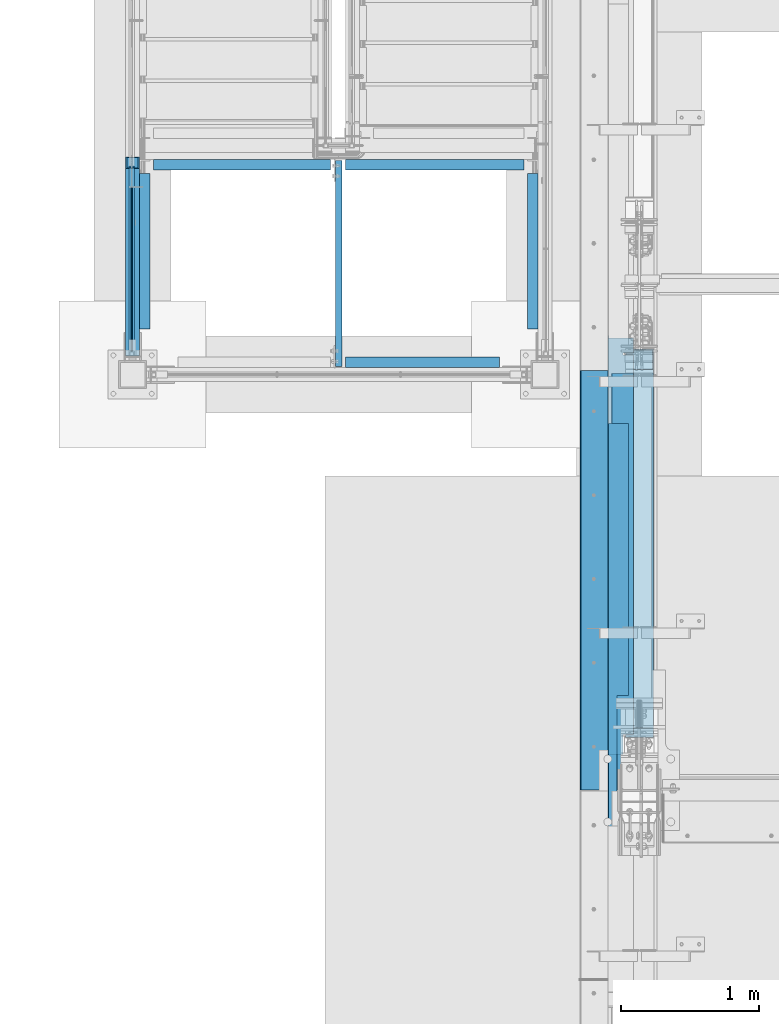
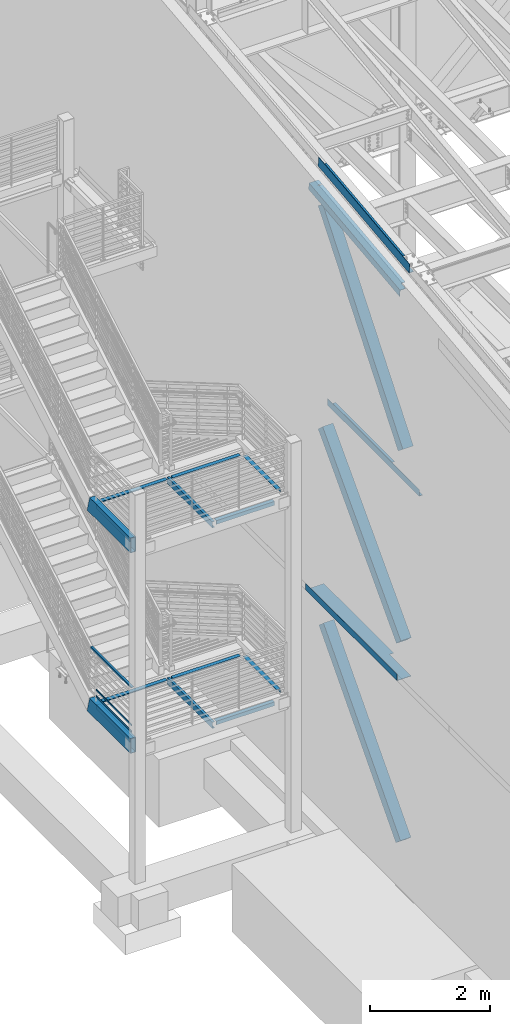
# One storey, part 729 of 1179: 21 beams, 3 members, 17 elements without a shape of their own.
"""IFC2X3 building model written with IfcOpenShell, lengths in millimetres."""

from ifc_helpers import new_model, si_unit, frame, origin_with_axes, place, context, subcontext, project, spatial, faceted_brep, material, type_object, element, aggregate, save


model = new_model("IFC2X3")

# Units and contexts
model_context = context("Model", 3, precision=1e-05, world=origin_with_axes())
body_context = subcontext(model_context, "Body", "Model", "MODEL_VIEW")
ifc_project = project(units=[si_unit("LENGTHUNIT", "METRE", prefix="MILLI"), si_unit("AREAUNIT", "SQUARE_METRE"), si_unit("VOLUMEUNIT", "CUBIC_METRE"), si_unit("MASSUNIT", "GRAM", prefix="KILO"), si_unit("TIMEUNIT", "SECOND"), si_unit("PLANEANGLEUNIT", "RADIAN"), si_unit("SOLIDANGLEUNIT", "STERADIAN"), si_unit("THERMODYNAMICTEMPERATUREUNIT", "DEGREE_CELSIUS"), si_unit("LUMINOUSINTENSITYUNIT", "LUMEN")], contexts=[model_context])

# Site, building, storey
site_placement = place(None, origin_with_axes())
site = spatial("IfcSite", under=ifc_project, at=site_placement, CompositionType="ELEMENT")
building_placement = place(site_placement, origin_with_axes())
building = spatial("IfcBuilding", under=site, at=building_placement, Name="Undefined", CompositionType="ELEMENT")
storey_placement = place(building_placement, origin_with_axes())
storey = spatial("IfcBuildingStorey", under=building, at=storey_placement, Name="Undefined", CompositionType="ELEMENT", Elevation=0.0)

# Assembly, beams
assembly_1_placement = place(storey_placement, origin_with_axes())
assembly_1 = element("IfcElementAssembly", 1, at=assembly_1_placement, inside=storey, Name="GUARDRAIL", AssemblyPlace="NOTDEFINED", PredefinedType="RIGID_FRAME")
ifc_material_1 = material(Name="STEEL/A36")
beam_type_1 = type_object("IfcBeamType", PredefinedType="NOTDEFINED")
beam_1_placement = place(assembly_1_placement, frame((-3257.54999923555, 31436.7340723971, 2406.68179561595), z_axis=(0.0, 0.0, 1.0), x_axis=(0.0, -1.0, 0.0)))
beam_1 = element("IfcBeam", 2, at=beam_1_placement, type_object=beam_type_1, material=ifc_material_1, Name="PLATE", context=body_context, shape_type="Brep", body=[
    faceted_brep([(4.76323658805632, 4.76249999999982, -19.0500000000002), (4.76323658805632, 4.76249999999982, 19.0500000000002), (1191.68407068639, 4.76249999999982, 19.0500000000002), (1191.68407068639, 4.76249999999982, -19.0500000000002), (4.76323658805632, -4.76249999999982, 19.0500000000002), (1191.68407068639, -4.76249999999982, 19.0500000000002), (4.76323658805632, -4.76249999999982, -19.0500000000002), (1191.68407068639, -4.76249999999982, -19.0500000000002)], [[[0, 1, 2, 3]], [[1, 4, 5, 2]], [[4, 6, 7, 5]], [[6, 0, 3, 7]], [[5, 7, 3, 2]], [[6, 4, 1, 0]]]),
])
beam_2_placement = place(assembly_1_placement, frame((-3257.54999923555, 31436.7340723971, 2276.50679561595), z_axis=(0.0, 0.0, 1.0), x_axis=(0.0, -1.0, 0.0)))
beam_2 = element("IfcBeam", 3, at=beam_2_placement, type_object=beam_type_1, material=ifc_material_1, Name="PLATE", context=body_context, shape_type="Brep", body=[
    faceted_brep([(4.76323658805632, 4.76249999999982, -19.0500000000002), (4.76323658805632, 4.76249999999982, 19.0500000000002), (1191.68407068639, 4.76249999999982, 19.0500000000002), (1191.68407068639, 4.76249999999982, -19.0500000000002), (4.76323658805632, -4.76249999999982, 19.0500000000002), (1191.68407068639, -4.76249999999982, 19.0500000000002), (4.76323658805632, -4.76249999999982, -19.0500000000002), (1191.68407068639, -4.76249999999982, -19.0500000000002)], [[[0, 1, 2, 3]], [[1, 4, 5, 2]], [[4, 6, 7, 5]], [[6, 0, 3, 7]], [[5, 7, 3, 2]], [[6, 4, 1, 0]]]),
])
ifc_material_2 = material()
beam_type_2 = type_object("IfcBeamType", Name="HSS1-1/2X1-1/2X1/4", PredefinedType="NOTDEFINED")
beam_3_placement = place(assembly_1_placement, frame((-3257.54999923555, 31590.0170040751, 3184.47208126713), z_axis=(0.0, 3.87960000080057e-05, 0.999999999247435), x_axis=(0.0, -0.999999999247435, 3.87960000097402e-05)))
beam_3 = element("IfcBeam", 4, at=beam_3_placement, type_object=beam_type_2, material=ifc_material_2, Name="GUARDRAIL", ObjectType="HSS1-1/2X1-1/2X1/4", context=body_context, shape_type="Brep", body=[
    faceted_brep([(1.79645228376103, 12.6999993300001, -12.6999993299992), (1.79645228376103, -12.6999993300001, -12.6999993299992), (1351.31651305502, -12.6999993300001, -12.6999993301542), (1351.31651305502, 12.6999993300001, -12.6999993301542), (8.61965151152981, -12.6999993300001, 12.6999993299983), (1376.71749714939, -12.6999993300001, 12.6999993298532), (8.61965151152981, 12.6999993300001, 12.6999993299983), (1376.71749714939, 12.6999993300001, 12.6999993298532), (0.090652412345662, 19.0499992350001, -19.0499992349992), (10.3254513829452, 19.0499992350001, 19.0499992349983), (1383.06774341299, 19.0499992350001, 19.049999234855), (1344.96626679142, 19.0499992350001, -19.049999235157), (10.3254513829452, -19.0499992350001, 19.0499992349983), (1383.06774341299, -19.0499992350001, 19.049999234855), (0.090652412345662, -19.0499992350001, -19.0499992349992), (1344.96626679142, -19.0499992350001, -19.049999235157)], [[[0, 1, 2, 3]], [[1, 4, 5, 2]], [[4, 6, 7, 5]], [[6, 0, 3, 7]], [[8, 9, 10, 11]], [[9, 12, 13, 10]], [[12, 14, 15, 13]], [[14, 8, 11, 15]], [[13, 15, 11, 10], [5, 7, 3, 2]], [[14, 12, 9, 8], [6, 4, 1, 0]]]),
])
aggregate(assembly_1, [beam_1, beam_2, beam_3])

# Assembly, beam
assembly_2_placement = place(storey_placement, origin_with_axes())
assembly_2 = element("IfcElementAssembly", 5, at=assembly_2_placement, inside=storey, Name="STRINGER", AssemblyPlace="NOTDEFINED", PredefinedType="RIGID_FRAME")
beam_type_3 = type_object("IfcBeamType", Name="L3X3X1/4", PredefinedType="NOTDEFINED")
beam_4_placement = place(assembly_2_placement, frame((-342.899999980288, 30403.7999999995, 6051.55), z_axis=(0.0, 0.0, -1.0), x_axis=(0.0, 1.0, 0.0)))
beam_4 = element("IfcBeam", 6, at=beam_4_placement, type_object=beam_type_3, material=ifc_material_1, Name="ANGLE", ObjectType="L3X3X1/4", context=body_context, shape_type="Brep", body=[
    faceted_brep([(0.0, 38.0999999999985, -38.0999999999999), (0.0, 38.0999999999985, 38.0999999999999), (1130.2999999998, 38.1, 38.1000000000004), (1130.2999999998, 38.1, -38.1000000000004), (0.0, 31.75, 38.1000000000004), (1130.2999999998, 31.75, 38.1000000000004), (0.0, 31.75, -31.75), (1130.2999999998, 31.75, -31.75), (0.0, -38.0999999999985, -31.75), (1130.2999999998, -38.1, -31.75), (0.0, -38.0999999999985, -38.0999999999999), (1130.2999999998, -38.1, -38.1000000000004)], [[[0, 1, 2, 3]], [[1, 4, 5, 2]], [[4, 6, 7, 5]], [[6, 8, 9, 7]], [[8, 10, 11, 9]], [[10, 0, 3, 11]], [[5, 7, 9, 11, 3, 2]], [[10, 8, 6, 4, 1, 0]]]),
])
aggregate(assembly_2, [beam_4])

assembly_3_placement = place(storey_placement, origin_with_axes())
assembly_3 = element("IfcElementAssembly", 7, at=assembly_3_placement, inside=storey, Name="STRINGER", AssemblyPlace="NOTDEFINED", PredefinedType="RIGID_FRAME")
beam_5_placement = place(assembly_3_placement, frame((-3162.30000000027, 30403.8, 6051.54999999882), z_axis=(1.0, 0.0, 0.0), x_axis=(0.0, 1.0, 0.0)))
beam_5 = element("IfcBeam", 8, at=beam_5_placement, type_object=beam_type_3, material=ifc_material_1, Name="ANGLE", ObjectType="L3X3X1/4", context=body_context, shape_type="Brep", body=[
    faceted_brep([(0.0, 38.0999999999985, -38.0999999999999), (0.0, 38.0999999999985, 38.0999999999999), (1130.2999999998, 38.1, 38.1000000000004), (1130.2999999998, 38.1, -38.1000000000004), (0.0, 31.75, 38.1000000000004), (1130.2999999998, 31.75, 38.1000000000004), (0.0, 31.75, -31.75), (1130.2999999998, 31.75, -31.75), (0.0, -38.0999999999985, -31.75), (1130.2999999998, -38.1, -31.75), (0.0, -38.0999999999985, -38.0999999999999), (1130.2999999998, -38.1, -38.1000000000004)], [[[0, 1, 2, 3]], [[1, 4, 5, 2]], [[4, 6, 7, 5]], [[6, 8, 9, 7]], [[8, 10, 11, 9]], [[10, 0, 3, 11]], [[5, 7, 9, 11, 3, 2]], [[10, 8, 6, 4, 1, 0]]]),
])

assembly_4_placement = place(storey_placement, origin_with_axes())
assembly_4 = element("IfcElementAssembly", 9, at=assembly_4_placement, inside=storey, Name="STRINGER", AssemblyPlace="NOTDEFINED", PredefinedType="RIGID_FRAME")
beam_6_placement = place(assembly_4_placement, frame((-3162.30000000013, 30403.8, 1978.025), z_axis=(1.0, 0.0, 0.0), x_axis=(0.0, 1.0, 0.0)))
beam_6 = element("IfcBeam", 10, at=beam_6_placement, type_object=beam_type_3, material=ifc_material_1, Name="ANGLE", ObjectType="L3X3X1/4", context=body_context, shape_type="Brep", body=[
    faceted_brep([(0.0, 38.0999999999985, -38.0999999999999), (0.0, 38.0999999999985, 38.0999999999999), (1130.2999999998, 38.1, 38.1000000000004), (1130.2999999998, 38.1, -38.1000000000004), (0.0, 31.75, 38.1000000000004), (1130.2999999998, 31.75, 38.1000000000004), (0.0, 31.75, -31.75), (1130.2999999998, 31.75, -31.75), (0.0, -38.0999999999985, -31.75), (1130.2999999998, -38.1, -31.75), (0.0, -38.0999999999985, -38.0999999999999), (1130.2999999998, -38.1, -38.1000000000004)], [[[0, 1, 2, 3]], [[1, 4, 5, 2]], [[4, 6, 7, 5]], [[6, 8, 9, 7]], [[8, 10, 11, 9]], [[10, 0, 3, 11]], [[5, 7, 9, 11, 3, 2]], [[10, 8, 6, 4, 1, 0]]]),
])

assembly_5_placement = place(storey_placement, origin_with_axes())
assembly_5 = element("IfcElementAssembly", 11, at=assembly_5_placement, inside=storey, Name="STRINGER", AssemblyPlace="NOTDEFINED", PredefinedType="RIGID_FRAME")
beam_7_placement = place(assembly_5_placement, frame((-342.900000030261, 30403.7999990904, 1978.025), z_axis=(0.0, 0.0, -1.0), x_axis=(0.0, 1.0, 0.0)))
beam_7 = element("IfcBeam", 12, at=beam_7_placement, type_object=beam_type_3, material=ifc_material_1, Name="ANGLE", ObjectType="L3X3X1/4", context=body_context, shape_type="Brep", body=[
    faceted_brep([(0.0, 38.0999999999985, -38.0999999999999), (0.0, 38.0999999999985, 38.0999999999999), (1130.2999999998, 38.1, 38.1000000000004), (1130.2999999998, 38.1, -38.1000000000004), (0.0, 31.75, 38.1000000000004), (1130.2999999998, 31.75, 38.1000000000004), (0.0, 31.75, -31.75), (1130.2999999998, 31.75, -31.75), (0.0, -38.0999999999985, -31.75), (1130.2999999998, -38.1, -31.75), (0.0, -38.0999999999985, -38.0999999999999), (1130.2999999998, -38.1, -38.1000000000004)], [[[0, 1, 2, 3]], [[1, 4, 5, 2]], [[4, 6, 7, 5]], [[6, 8, 9, 7]], [[8, 10, 11, 9]], [[10, 0, 3, 11]], [[5, 7, 9, 11, 3, 2]], [[10, 8, 6, 4, 1, 0]]]),
])
aggregate(assembly_5, [beam_7])

assembly_6_placement = place(storey_placement, origin_with_axes())
assembly_6 = element("IfcElementAssembly", 13, at=assembly_6_placement, inside=storey, Name="BEAM", AssemblyPlace="NOTDEFINED", PredefinedType="RIGID_FRAME")
beam_8_placement = place(assembly_6_placement, frame((-3098.80000000018, 31597.5999999997, 6051.54999999882), z_axis=(0.0, -1.0, 0.0), x_axis=(1.0, 0.0, 0.0)))
beam_8 = element("IfcBeam", 14, at=beam_8_placement, type_object=beam_type_3, material=ifc_material_1, Name="ANGLE", ObjectType="L3X3X1/4", context=body_context, shape_type="Brep", body=[
    faceted_brep([(0.0, 38.0999999999985, -38.0999999999999), (0.0, 38.0999999999985, 38.0999999999999), (1287.46249994958, 38.1000000000004, 38.0999999999985), (1287.46249994958, 38.1000000000004, -38.0999999999985), (0.0, 31.75, 38.1000000000004), (1287.46249994958, 31.75, 38.0999999999985), (0.0, 31.75, -31.75), (1287.46249994958, 31.75, -31.75), (0.0, -38.0999999999985, -31.75), (1287.46249994958, -38.1000000000004, -31.75), (0.0, -38.0999999999985, -38.0999999999999), (1287.46249994958, -38.1000000000004, -38.0999999999985)], [[[0, 1, 2, 3]], [[1, 4, 5, 2]], [[4, 6, 7, 5]], [[6, 8, 9, 7]], [[8, 10, 11, 9]], [[10, 0, 3, 11]], [[5, 7, 9, 11, 3, 2]], [[10, 8, 6, 4, 1, 0]]]),
])

# Assembly, beams
assembly_7_placement = place(storey_placement, origin_with_axes())
assembly_7 = element("IfcElementAssembly", 15, at=assembly_7_placement, inside=storey, Name="BEAM", AssemblyPlace="NOTDEFINED", PredefinedType="RIGID_FRAME")
beam_9_placement = place(assembly_7_placement, frame((-3098.80000000018, 31597.6, 1978.025), z_axis=(0.0, -1.0, 0.0), x_axis=(1.0, 0.0, 0.0)))
beam_9 = element("IfcBeam", 16, at=beam_9_placement, type_object=beam_type_3, material=ifc_material_1, Name="ANGLE", ObjectType="L3X3X1/4", context=body_context, shape_type="Brep", body=[
    faceted_brep([(0.0, 38.0999999999985, -38.0999999999999), (0.0, 38.0999999999985, 38.0999999999999), (1287.46249994958, 38.1000000000004, 38.0999999999985), (1287.46249994958, 38.1000000000004, -38.0999999999985), (0.0, 31.75, 38.1000000000004), (1287.46249994958, 31.75, 38.0999999999985), (0.0, 31.75, -31.75), (1287.46249994958, 31.75, -31.75), (0.0, -38.0999999999985, -31.75), (1287.46249994958, -38.1000000000004, -31.75), (0.0, -38.0999999999985, -38.0999999999999), (1287.46249994958, -38.1000000000004, -38.0999999999985)], [[[0, 1, 2, 3]], [[1, 4, 5, 2]], [[4, 6, 7, 5]], [[6, 8, 9, 7]], [[8, 10, 11, 9]], [[10, 0, 3, 11]], [[5, 7, 9, 11, 3, 2]], [[10, 8, 6, 4, 1, 0]]]),
])
beam_10_placement = place(assembly_7_placement, frame((-1703.3875, 31597.6000000001, 1978.025), z_axis=(0.0, -1.0, 0.0), x_axis=(1.0, 0.0, 0.0)))
beam_10 = element("IfcBeam", 17, at=beam_10_placement, type_object=beam_type_3, material=ifc_material_1, Name="ANGLE", ObjectType="L3X3X1/4", context=body_context, shape_type="Brep", body=[
    faceted_brep([(0.0, 38.0999999999985, -38.0999999999999), (0.0, 38.0999999999985, 38.0999999999999), (1296.98749999999, 38.0999999999999, 38.0999999999985), (1296.98749999999, 38.0999999999999, -38.0999999999985), (0.0, 31.75, 38.1000000000004), (1296.98749999999, 31.75, 38.0999999999985), (0.0, 31.75, -31.75), (1296.98749999999, 31.75, -31.75), (0.0, -38.0999999999985, -31.75), (1296.98749999999, -38.0999999999999, -31.75), (0.0, -38.0999999999985, -38.0999999999999), (1296.98749999999, -38.0999999999999, -38.0999999999985)], [[[0, 1, 2, 3]], [[1, 4, 5, 2]], [[4, 6, 7, 5]], [[6, 8, 9, 7]], [[8, 10, 11, 9]], [[10, 0, 3, 11]], [[5, 7, 9, 11, 3, 2]], [[10, 8, 6, 4, 1, 0]]]),
])
aggregate(assembly_7, [beam_9, beam_10])

# Beam
beam_11_placement = place(assembly_6_placement, frame((-1703.3875, 31597.6, 6051.55), z_axis=(0.0, -1.0, 0.0), x_axis=(1.0, 0.0, 0.0)))
beam_11 = element("IfcBeam", 18, at=beam_11_placement, type_object=beam_type_3, material=ifc_material_1, Name="ANGLE", ObjectType="L3X3X1/4", context=body_context, shape_type="Brep", body=[
    faceted_brep([(0.0, 38.0999999999985, -38.0999999999999), (0.0, 38.0999999999985, 38.0999999999999), (1296.98749999999, 38.0999999999999, 38.0999999999985), (1296.98749999999, 38.0999999999999, -38.0999999999985), (0.0, 31.75, 38.1000000000004), (1296.98749999999, 31.75, 38.0999999999985), (0.0, 31.75, -31.75), (1296.98749999999, 31.75, -31.75), (0.0, -38.0999999999985, -31.75), (1296.98749999999, -38.0999999999999, -31.75), (0.0, -38.0999999999985, -38.0999999999999), (1296.98749999999, -38.0999999999999, -38.0999999999985)], [[[0, 1, 2, 3]], [[1, 4, 5, 2]], [[4, 6, 7, 5]], [[6, 8, 9, 7]], [[8, 10, 11, 9]], [[10, 0, 3, 11]], [[5, 7, 9, 11, 3, 2]], [[10, 8, 6, 4, 1, 0]]]),
])

aggregate(assembly_6, [beam_8, beam_11])

# Assembly, beam
assembly_8_placement = place(storey_placement, origin_with_axes())
assembly_8 = element("IfcElementAssembly", 19, at=assembly_8_placement, inside=storey, Name="BEAM", AssemblyPlace="NOTDEFINED", PredefinedType="RIGID_FRAME")
beam_12_placement = place(assembly_8_placement, frame((-1703.3875, 30162.5, 1978.025), z_axis=(0.0, 0.0, -1.0), x_axis=(1.0, 0.0, 0.0)))
beam_12 = element("IfcBeam", 20, at=beam_12_placement, type_object=beam_type_3, material=ifc_material_1, Name="ANGLE", ObjectType="L3X3X1/4", context=body_context, shape_type="Brep", body=[
    faceted_brep([(0.0, 38.0999999999985, -38.0999999999999), (0.0, 38.0999999999985, 38.0999999999999), (1119.1875, 38.1000000000004, 38.0999999999985), (1119.1875, 38.1000000000004, -38.0999999999985), (0.0, 31.75, 38.1000000000004), (1119.1875, 31.75, 38.0999999999985), (0.0, 31.75, -31.75), (1119.1875, 31.75, -31.75), (0.0, -38.0999999999985, -31.75), (1119.1875, -38.1000000000004, -31.75), (0.0, -38.0999999999985, -38.0999999999999), (1119.1875, -38.1000000000004, -38.0999999999985)], [[[0, 1, 2, 3]], [[1, 4, 5, 2]], [[4, 6, 7, 5]], [[6, 8, 9, 7]], [[8, 10, 11, 9]], [[10, 0, 3, 11]], [[5, 7, 9, 11, 3, 2]], [[10, 8, 6, 4, 1, 0]]]),
])
aggregate(assembly_8, [beam_12])

assembly_9_placement = place(storey_placement, origin_with_axes())
assembly_9 = element("IfcElementAssembly", 21, at=assembly_9_placement, inside=storey, Name="BEAM", AssemblyPlace="NOTDEFINED", PredefinedType="RIGID_FRAME")
beam_13_placement = place(assembly_9_placement, frame((-1703.3875, 30162.5, 6051.55), z_axis=(0.0, 0.0, -1.0), x_axis=(1.0, 0.0, 0.0)))
beam_13 = element("IfcBeam", 22, at=beam_13_placement, type_object=beam_type_3, material=ifc_material_1, Name="ANGLE", ObjectType="L3X3X1/4", context=body_context, shape_type="Brep", body=[
    faceted_brep([(0.0, 38.0999999999985, -38.0999999999999), (0.0, 38.0999999999985, 38.0999999999999), (1119.1875, 38.1000000000004, 38.0999999999985), (1119.1875, 38.1000000000004, -38.0999999999985), (0.0, 31.75, 38.1000000000004), (1119.1875, 31.75, 38.0999999999985), (0.0, 31.75, -31.75), (1119.1875, 31.75, -31.75), (0.0, -38.0999999999985, -31.75), (1119.1875, -38.1000000000004, -31.75), (0.0, -38.0999999999985, -38.0999999999999), (1119.1875, -38.1000000000004, -38.0999999999985)], [[[0, 1, 2, 3]], [[1, 4, 5, 2]], [[4, 6, 7, 5]], [[6, 8, 9, 7]], [[8, 10, 11, 9]], [[10, 0, 3, 11]], [[5, 7, 9, 11, 3, 2]], [[10, 8, 6, 4, 1, 0]]]),
])
aggregate(assembly_9, [beam_13])

assembly_10_placement = place(storey_placement, origin_with_axes())
assembly_10 = element("IfcElementAssembly", 23, at=assembly_10_placement, inside=storey, Name="BEAM", AssemblyPlace="NOTDEFINED", PredefinedType="RIGID_FRAME")
beam_type_4 = type_object("IfcBeamType", Name="C5X9", PredefinedType="NOTDEFINED")
beam_14_placement = place(assembly_10_placement, frame((-1752.6, 30073.6, 6026.15), z_axis=(0.0, 0.0, 1.0), x_axis=(0.0, 1.0, 0.0)))
beam_14 = element("IfcBeam", 24, at=beam_14_placement, type_object=beam_type_4, material=ifc_material_1, Name="BEAM", ObjectType="C5X9", context=body_context, shape_type="Brep", body=[
    faceted_brep([(57.1499999999978, 23.8125, -63.5), (57.1499999999978, 23.8125, 63.5), (1555.75, 23.8125, 63.5), (1555.75, 23.8125, -63.5), (57.1499999999978, -23.8125, 63.5), (1555.75, -23.8125, 63.5), (57.1499999999978, -23.8125, 59.5296625000001), (1555.75, -23.8125, 59.5296625000001), (57.1499999999978, 15.875, 52.9177250000002), (1555.75, 15.875, 52.9177250000002), (57.1499999999978, 15.875, -52.9177250000002), (1555.75, 15.875, -52.9177250000002), (57.1499999999978, -23.8125, -59.5296625000001), (1555.75, -23.8125, -59.5296625000001), (57.1499999999978, -23.8125, -63.5), (1555.75, -23.8125, -63.5)], [[[0, 1, 2, 3]], [[1, 4, 5, 2]], [[4, 6, 7, 5]], [[6, 8, 9, 7]], [[8, 10, 11, 9]], [[10, 12, 13, 11]], [[12, 14, 15, 13]], [[14, 0, 3, 15]], [[5, 7, 9, 11, 13, 15, 3, 2]], [[14, 12, 10, 8, 6, 4, 1, 0]]]),
])
aggregate(assembly_10, [beam_14])

assembly_11_placement = place(storey_placement, origin_with_axes())
assembly_11 = element("IfcElementAssembly", 25, at=assembly_11_placement, inside=storey, Name="BEAM", AssemblyPlace="NOTDEFINED", PredefinedType="RIGID_FRAME")
beam_15_placement = place(assembly_11_placement, frame((-1752.6, 30073.6, 1952.625), z_axis=(0.0, 0.0, 1.0), x_axis=(0.0, 1.0, 0.0)))
beam_15 = element("IfcBeam", 26, at=beam_15_placement, type_object=beam_type_4, material=ifc_material_1, Name="BEAM", ObjectType="C5X9", context=body_context, shape_type="Brep", body=[
    faceted_brep([(57.1499999999978, 23.8125, -63.5), (57.1499999999978, 23.8125, 63.5), (1555.75, 23.8125, 63.5), (1555.75, 23.8125, -63.5), (57.1499999999978, -23.8125, 63.5), (1555.75, -23.8125, 63.5), (57.1499999999978, -23.8125, 59.5296625000001), (1555.75, -23.8125, 59.5296625000001), (57.1499999999978, 15.875, 52.9177250000002), (1555.75, 15.875, 52.9177250000002), (57.1499999999978, 15.875, -52.9177250000002), (1555.75, 15.875, -52.9177250000002), (57.1499999999978, -23.8125, -59.5296625000001), (1555.75, -23.8125, -59.5296625000001), (57.1499999999978, -23.8125, -63.5), (1555.75, -23.8125, -63.5)], [[[0, 1, 2, 3]], [[1, 4, 5, 2]], [[4, 6, 7, 5]], [[6, 8, 9, 7]], [[8, 10, 11, 9]], [[10, 12, 13, 11]], [[12, 14, 15, 13]], [[14, 0, 3, 15]], [[5, 7, 9, 11, 13, 15, 3, 2]], [[14, 12, 10, 8, 6, 4, 1, 0]]]),
])
aggregate(assembly_11, [beam_15])

assembly_12_placement = place(storey_placement, origin_with_axes())
assembly_12 = element("IfcElementAssembly", 27, at=assembly_12_placement, inside=storey, Name="BEAM", AssemblyPlace="NOTDEFINED", PredefinedType="RIGID_FRAME")
beam_type_5 = type_object("IfcBeamType", PredefinedType="NOTDEFINED")
beam_16_placement = place(assembly_12_placement, frame((388.937000000002, 28568.0759537217, 12478.2300352794), z_axis=(0.0, -0.993676146336441, -0.112284087038017), x_axis=(-1.0, 0.0, 0.0)))
beam_16 = element("IfcBeam", 28, at=beam_16_placement, type_object=beam_type_5, material=ifc_material_1, Name="BENT_PLATE", context=body_context, shape_type="Brep", body=[
    faceted_brep([(71.436748188231, -3.17500000044856, 1106.33418420742), (71.4367827558929, 3.23873428631487, 1106.33516467817), (-1.27897692436818e-11, 3.17499999954816, 1106.33518727968), (-1.27897692436818e-11, -3.17500000044856, 1106.33420675007), (71.4368094667368, -3.17499887494341, 1523.99263642799), (71.4368436902772, 3.174999999379, 1523.99999999914), (153.98700000004, -3.17499999938263, -1523.99999999915), (0.0, -3.17499999999927, -1524.0), (0.0, 3.17499999999927, -1524.0), (160.33700000004, 3.17500000061409, -1523.99999999915), (160.337000000008, -187.324999998866, -1523.99999999923), (153.987000000008, -187.324999998866, -1523.99999999923), (160.336999999976, 3.174999999379, 1523.99999999915), (160.337000000008, -187.325000000099, 1523.99999999907), (153.987000000008, -187.325000000099, 1523.99999999907), (153.986999999976, -3.17500000061773, 1523.99999999914)], [[[0, 1, 2, 3]], [[4, 5, 1, 0]], [[6, 7, 8, 9, 10, 11]], [[9, 12, 13, 10]], [[14, 11, 10, 13]], [[15, 6, 11, 14]], [[3, 7, 6, 15, 4, 0]], [[8, 7, 3, 2]], [[12, 9, 8, 2, 1, 5]], [[15, 14, 13, 12, 5, 4]]]),
])

# Beam
beam_type_6 = type_object("IfcBeamType", Name="HSS12X4X3/8", PredefinedType="NOTDEFINED")
beam_17_placement = place(assembly_3_placement, frame((-3251.20000000031, 31571.1662663812, 6089.65000000228), z_axis=(0.0, 0.0, 1.0), x_axis=(0.0, -1.0, 0.0)))
beam_17 = element("IfcBeam", 29, at=beam_17_placement, type_object=beam_type_6, material=ifc_material_2, Name="STRINGER", ObjectType="HSS12X4X3/8", context=body_context, shape_type="Brep", body=[
    faceted_brep([(-79.8273428607608, 41.2750000000015, -142.874999999865), (-79.8273428607608, -41.2750000000015, -142.874999999865), (1361.04126637977, -41.2750000000001, -142.875), (1361.04126637977, 41.2750000000001, -142.875), (-2.57507558227371, -41.2750000000015, 142.874999999935), (1361.04126637977, -41.2750000000001, 142.875), (-2.57507558227371, 41.2750000000015, 142.874999999935), (1361.04126637977, 41.2750000000001, 142.875), (-82.4024182638459, 50.8000000000002, -152.4), (0.0, 50.8000000000029, 152.4), (1361.04126637977, 50.8000000000002, 152.4), (1361.04126637977, 50.8000000000002, -152.4), (0.0, -50.8000000000029, 152.4), (1361.04126637977, -50.8000000000002, 152.4), (-82.4024182638459, -50.8000000000002, -152.4), (1361.04126637977, -50.8000000000002, -152.4)], [[[0, 1, 2, 3]], [[1, 4, 5, 2]], [[4, 6, 7, 5]], [[6, 0, 3, 7]], [[8, 9, 10, 11]], [[9, 12, 13, 10]], [[12, 14, 15, 13]], [[14, 8, 11, 15]], [[13, 15, 11, 10], [5, 7, 3, 2]], [[14, 12, 9, 8], [6, 4, 1, 0]]]),
])

aggregate(assembly_3, [beam_5, beam_17])

beam_18_placement = place(assembly_4_placement, frame((-3251.20000000004, 31571.2546584537, 2016.12499999985), z_axis=(0.0, 0.0, 1.0), x_axis=(0.0, -1.0, 0.0)))
beam_18 = element("IfcBeam", 30, at=beam_18_placement, type_object=beam_type_6, material=ifc_material_2, Name="STRINGER", ObjectType="HSS12X4X3/8", context=body_context, shape_type="Brep", body=[
    faceted_brep([(-79.3135540918956, 41.2750000000001, -142.875), (-79.3135540918956, -41.2750000000001, -142.875), (1361.22936526286, -41.2750000000001, -142.875), (1361.22936526286, 41.2750000000001, -142.875), (-2.55850173872022, -41.2750000000001, 142.875), (1361.22936526286, -41.2750000000001, 142.875), (-2.55850173872022, 41.2750000000001, 142.875), (1361.22936526286, 41.2750000000001, 142.875), (-81.8720558370042, 50.8000000000002, -152.4), (0.0, 50.8000000000029, 152.4), (1361.22936526286, 50.8000000000002, 152.4), (1361.22936526286, 50.8000000000002, -152.4), (0.0, -50.8000000000029, 152.4), (1361.22936526286, -50.8000000000002, 152.4), (-81.8720558370042, -50.8000000000002, -152.4), (1361.22936526286, -50.8000000000002, -152.4)], [[[0, 1, 2, 3]], [[1, 4, 5, 2]], [[4, 6, 7, 5]], [[6, 0, 3, 7]], [[8, 9, 10, 11]], [[9, 12, 13, 10]], [[12, 14, 15, 13]], [[14, 8, 11, 15]], [[13, 15, 11, 10], [5, 7, 3, 2]], [[14, 12, 9, 8], [6, 4, 1, 0]]]),
])

aggregate(assembly_4, [beam_6, beam_18])

# Assembly, member
assembly_13_placement = place(storey_placement, origin_with_axes())
assembly_13 = element("IfcElementAssembly", 31, at=assembly_13_placement, inside=storey, Name="None", AssemblyPlace="NOTDEFINED", PredefinedType="RIGID_FRAME")
ifc_material_3 = material(Name="STEEL/A992")
member_type = type_object("IfcMemberType", Name="HSS8X8X3/16", PredefinedType="NOTDEFINED")
member_1_placement = place(assembly_13_placement, frame((431.800000000002, 27516.3854983669, 8392.213637827), z_axis=(1.0, 0.0, 0.0), x_axis=(0.0, 0.620567780308726, 0.784152810390106)))
member_1 = element("IfcMember", 32, at=member_1_placement, type_object=member_type, material=ifc_material_3, Name="None", ObjectType="HSS8X8X3/16", context=body_context, shape_type="Brep", body=[
    faceted_brep([(-3.63797880709171e-12, 96.8374999999978, -96.8375000000015), (-3.63797880709171e-12, -96.8374999999978, -96.8375000000015), (4291.32999998814, -96.8374999960452, -96.8375), (4291.32999998818, 96.8375000037358, -96.8375), (-3.63797880709171e-12, -96.8374999999978, 96.8375000000015), (4291.32999998814, -96.8374999960452, 96.8375), (-3.63797880709171e-12, 96.8374999999978, 96.8375000000015), (4291.32999998818, 96.8375000037358, 96.8375), (-3.63797880709171e-12, 101.599999999999, -101.599999999999), (-3.63797880709171e-12, 101.599999999999, 101.599999999999), (4291.32999998818, 101.600000003729, 101.6), (4291.32999998818, 101.600000003729, -101.6), (0.0, -101.599999999999, 101.599999999999), (4291.32999998813, -101.599999996035, 101.6), (0.0, -101.599999999999, -101.599999999999), (4291.32999998813, -101.599999996035, -101.6)], [[[0, 1, 2, 3]], [[1, 4, 5, 2]], [[4, 6, 7, 5]], [[6, 0, 3, 7]], [[8, 9, 10, 11]], [[9, 12, 13, 10]], [[12, 14, 15, 13]], [[14, 8, 11, 15]], [[13, 15, 11, 10], [5, 7, 3, 2]], [[14, 12, 9, 8], [6, 4, 1, 0]]]),
])
aggregate(assembly_13, [member_1])

assembly_14_placement = place(storey_placement, origin_with_axes())
assembly_14 = element("IfcElementAssembly", 33, at=assembly_14_placement, inside=storey, Name="None", AssemblyPlace="NOTDEFINED", PredefinedType="RIGID_FRAME")
member_2_placement = place(assembly_14_placement, frame((431.800000000002, 27577.7634105278, 4453.9449151374), z_axis=(1.0, 0.0, 0.0), x_axis=(0.0, 0.684256097894612, 0.729241792887681)))
member_2 = element("IfcMember", 34, at=member_2_placement, type_object=member_type, material=ifc_material_3, Name="None", ObjectType="HSS8X8X3/16", context=body_context, shape_type="Brep", body=[
    faceted_brep([(-3.63797880709171e-12, 96.8374999999978, -96.8375000000015), (-3.63797880709171e-12, -96.8374999999978, -96.8375000000015), (3806.84458407234, -96.837499991303, -96.8375), (3806.84458407192, 96.8375000092055, -96.8375), (-3.63797880709171e-12, -96.8374999999978, 96.8375000000015), (3806.84458407234, -96.837499991303, 96.8375), (-3.63797880709171e-12, 96.8374999999978, 96.8375000000015), (3806.84458407192, 96.8375000092055, 96.8375), (-3.63797880709171e-12, 101.599999999999, -101.599999999999), (-3.63797880709171e-12, 101.599999999999, 101.599999999999), (3806.84458407191, 101.600000009224, 101.6), (3806.84458407191, 101.600000009224, -101.6), (0.0, -101.599999999999, 101.599999999999), (3806.84458407235, -101.599999991318, 101.6), (0.0, -101.599999999999, -101.599999999999), (3806.84458407235, -101.599999991318, -101.6)], [[[0, 1, 2, 3]], [[1, 4, 5, 2]], [[4, 6, 7, 5]], [[6, 0, 3, 7]], [[8, 9, 10, 11]], [[9, 12, 13, 10]], [[12, 14, 15, 13]], [[14, 8, 11, 15]], [[13, 15, 11, 10], [5, 7, 3, 2]], [[14, 12, 9, 8], [6, 4, 1, 0]]]),
])
aggregate(assembly_14, [member_2])

assembly_15_placement = place(storey_placement, origin_with_axes())
assembly_15 = element("IfcElementAssembly", 35, at=assembly_15_placement, inside=storey, Name="None", AssemblyPlace="NOTDEFINED", PredefinedType="RIGID_FRAME")
member_3_placement = place(assembly_15_placement, frame((431.800000000002, 27593.1372284059, 390.956032270437), z_axis=(1.0, 0.0, 0.0), x_axis=(0.0, 0.666221892712437, 0.74575357167811)))
member_3 = element("IfcMember", 36, at=member_3_placement, type_object=member_type, material=ifc_material_3, Name="None", ObjectType="HSS8X8X3/16", context=body_context, shape_type="Brep", body=[
    faceted_brep([(-3.63797880709171e-12, 96.8374999999978, -96.8375000000015), (-3.63797880709171e-12, -96.8374999999978, -96.8375000000015), (3846.83000006713, -96.8375000095293, -96.8375), (3846.83000006755, 96.837499989997, -96.8375), (-3.63797880709171e-12, -96.8374999999978, 96.8375000000015), (3846.83000006713, -96.8375000095293, 96.8375), (-3.63797880709171e-12, 96.8374999999978, 96.8375000000015), (3846.83000006755, 96.837499989997, 96.8375), (-3.63797880709171e-12, 101.599999999999, -101.599999999999), (-3.63797880709171e-12, 101.599999999999, 101.599999999999), (3846.83000006756, 101.59999998999, 101.6), (3846.83000006756, 101.59999998999, -101.6), (0.0, -101.599999999999, 101.599999999999), (3846.83000006712, -101.600000009519, 101.6), (0.0, -101.599999999999, -101.599999999999), (3846.83000006712, -101.600000009519, -101.6)], [[[0, 1, 2, 3]], [[1, 4, 5, 2]], [[4, 6, 7, 5]], [[6, 0, 3, 7]], [[8, 9, 10, 11]], [[9, 12, 13, 10]], [[12, 14, 15, 13]], [[14, 8, 11, 15]], [[13, 15, 11, 10], [5, 7, 3, 2]], [[14, 12, 9, 8], [6, 4, 1, 0]]]),
])
aggregate(assembly_15, [member_3])

# Beam
beam_type_7 = type_object("IfcBeamType", PredefinedType="NOTDEFINED")
beam_19_placement = place(assembly_12_placement, frame((388.937000225636, 28826.0689489842, 11978.5769225911), z_axis=(0.0, -0.993676146336441, -0.112284087038017), x_axis=(-1.0, 0.0, 0.0)))
beam_19 = element("IfcBeam", 37, at=beam_19_placement, type_object=beam_type_7, material=ifc_material_1, Name="BENT_PLATE", context=body_context, shape_type="Brep", body=[
    faceted_brep([(76.1995002256102, -3.17544646840361, -1412.98904204309), (76.1995002256102, 3.17516714541489, -1412.9890420431), (-1.4210854715202e-11, 3.17500000057044, -1412.9890420431), (-1.3926637620898e-11, -3.17499999942811, -1412.98904204309), (76.1995002256102, -3.17544646841088, -1397.11404204329), (76.1995002256102, 3.17516714540761, -1397.11404204326), (-1.37561073643155e-11, -3.17499999943357, -1397.11404204329), (-1.40971678774804e-11, 3.17500000056316, -1397.11404204326), (185.737000203274, -3.17500000222026, 1523.9999999998), (185.737000201926, -3.17500000083055, -1523.99999999987), (185.737000202255, 136.524999793486, -1523.99999999991), (185.737000202948, 136.524999792873, 1523.99999999976), (76.1995001797359, -3.17550574784764, 1377.95000001703), (76.1995001797359, 3.17510786590537, 1377.95000001449), (7.27595761418343e-12, 3.17500000055588, 1377.94999996396), (7.27595761418343e-12, -3.1749999994372, 1377.94999996142), (76.1995001797359, -3.1750000051652, 1524.00000000082), (76.1995002269396, 3.17500000061045, 1523.99999999914), (179.387000202948, 136.524999792875, 1523.99999999976), (179.387000203274, 3.1749999978274, 1523.9999999998), (179.387000201926, 3.17499999921893, -1523.99999999987), (179.387000202255, 136.524999793486, -1523.99999999991), (0.0, -3.17499999999927, -1524.0), (0.0, 3.17499999999927, -1524.0)], [[[0, 1, 2, 3]], [[4, 5, 1, 0]], [[6, 7, 5, 4]], [[8, 9, 10, 11]], [[12, 13, 14, 15]], [[16, 17, 13, 12]], [[8, 11, 18, 19, 17, 16]], [[20, 19, 18, 21]], [[11, 10, 21, 18]], [[9, 22, 23, 20, 21, 10]], [[23, 22, 3, 2]], [[14, 13, 17, 19, 20, 23, 2, 1, 5, 7]], [[15, 14, 7, 6]], [[3, 22, 9, 8, 16, 12, 15, 6, 4, 0]]]),
])

aggregate(assembly_12, [beam_16, beam_19])

# Assembly, beam
assembly_16_placement = place(storey_placement, origin_with_axes())
assembly_16 = element("IfcElementAssembly", 38, at=assembly_16_placement, inside=storey, Name="BEAM", AssemblyPlace="NOTDEFINED", PredefinedType="RIGID_FRAME")
beam_type_8 = type_object("IfcBeamType", PredefinedType="NOTDEFINED")
beam_20_placement = place(assembly_16_placement, frame((352.424987792969, 28578.175, 4105.275), z_axis=(0.0, -1.0, 0.0), x_axis=(-1.0, 0.0, 0.0)))
beam_20 = element("IfcBeam", 39, at=beam_20_placement, type_object=beam_type_8, material=ifc_material_1, Name="BENT_PLATE", context=body_context, shape_type="Brep", body=[
    faceted_brep([(84.1374893188477, -3.17500000000018, 801.466996577077), (84.1374893188477, 3.17500000000018, 801.466996577077), (0.0, 3.17500000000018, 801.466996577077), (0.0, -3.17500000000018, 801.466996577077), (84.1374893188477, -3.17500000000018, 1524.0), (84.1374893188477, 3.17500000000018, 1524.0), (346.074987792969, -3.17500000000109, -1524.0), (0.0, -3.17499999999927, -1524.0), (0.0, 3.17499999999927, -1524.0), (352.424987792969, 3.17499999999927, -1524.0), (352.424987792969, -130.175006103515, -1524.0), (346.074987792969, -130.175006103515, -1524.0), (352.424987792969, 3.17499999999927, 1524.0), (352.424987792969, -130.175006103515, 1524.0), (346.074987792969, -130.175006103515, 1524.0), (346.074987792969, -3.17500000000109, 1524.0)], [[[0, 1, 2, 3]], [[4, 5, 1, 0]], [[6, 7, 8, 9, 10, 11]], [[9, 12, 13, 10]], [[14, 11, 10, 13]], [[15, 6, 11, 14]], [[3, 7, 6, 15, 4, 0]], [[8, 7, 3, 2]], [[12, 9, 8, 2, 1, 5]], [[15, 14, 13, 12, 5, 4]]]),
])
aggregate(assembly_16, [beam_20])

assembly_17_placement = place(storey_placement, origin_with_axes())
assembly_17 = element("IfcElementAssembly", 40, at=assembly_17_placement, inside=storey, Name="BEAM", AssemblyPlace="NOTDEFINED", PredefinedType="RIGID_FRAME")
beam_type_9 = type_object("IfcBeamType", PredefinedType="NOTDEFINED")
beam_21_placement = place(assembly_17_placement, frame((352.425002773815, 28193.9999997154, 8016.875), z_axis=(0.0, 1.0, 0.0), x_axis=(-1.0, 0.0, 0.0)))
beam_21 = element("IfcBeam", 41, at=beam_21_placement, type_object=beam_type_9, material=ifc_material_1, Name="BENT_PLATE", context=body_context, shape_type="Brep", body=[
    faceted_brep([(84.1375143233424, -3.17499999158008, -451.985749241001), (84.1375140629924, 3.17500000842028, -451.985749241001), (84.1375001249347, 3.17500000842028, -1523.99999999989), (84.1375003852847, -3.17499999158008, -1523.99999999989), (5.1988990890095e-10, -3.17500000000018, -451.985749242627), (-1.15562670544023e-10, 3.17500000000109, -451.985749242627), (142.874999594209, 3.17500001429835, 1524.00000000019), (6.00266503170133e-10, 3.17500000077416, 1524.00000000052), (6.00266503170133e-10, -3.17499999922438, 1524.00000000052), (149.224999854553, -3.17499998506719, 1524.0000000002), (149.224994388142, 130.17501236655, 1524.00000000027), (142.874994388142, 130.175012106208, 1524.00000000026), (142.874999597148, 3.17500001429835, -1523.99999999981), (142.874994389486, 130.175012107767, -1523.99999999974), (149.224994389486, 130.175012368109, -1523.99999999973), (149.224999857492, -3.17499998506719, -1523.9999999998)], [[[0, 1, 2, 3]], [[4, 5, 1, 0]], [[6, 7, 8, 9, 10, 11]], [[12, 6, 11, 13]], [[10, 14, 13, 11]], [[9, 15, 14, 10]], [[12, 13, 14, 15, 3, 2]], [[7, 6, 12, 2, 1, 5]], [[8, 7, 5, 4]], [[15, 9, 8, 4, 0, 3]]]),
])
aggregate(assembly_17, [beam_21])

save(model, "model.ifc")
